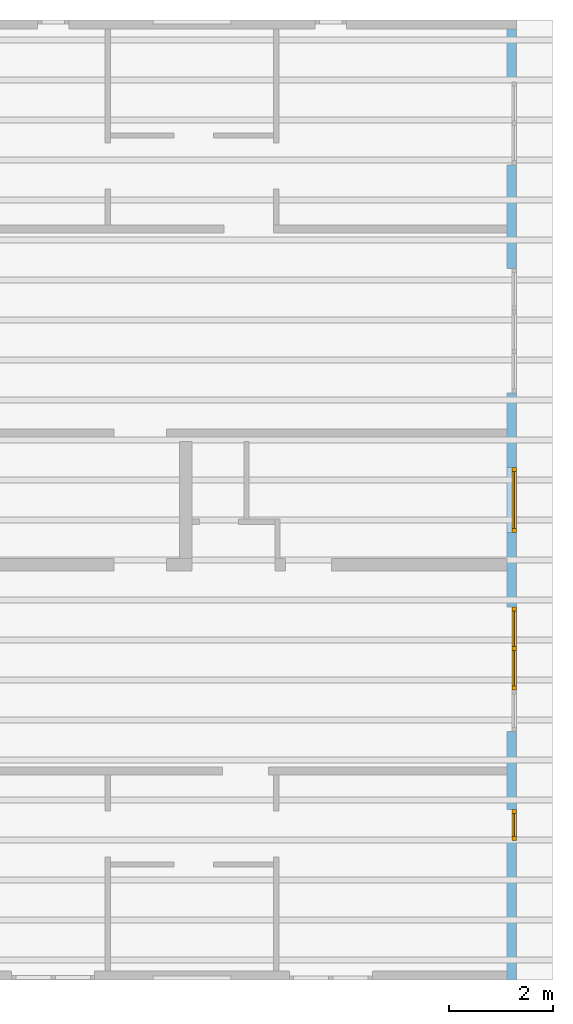
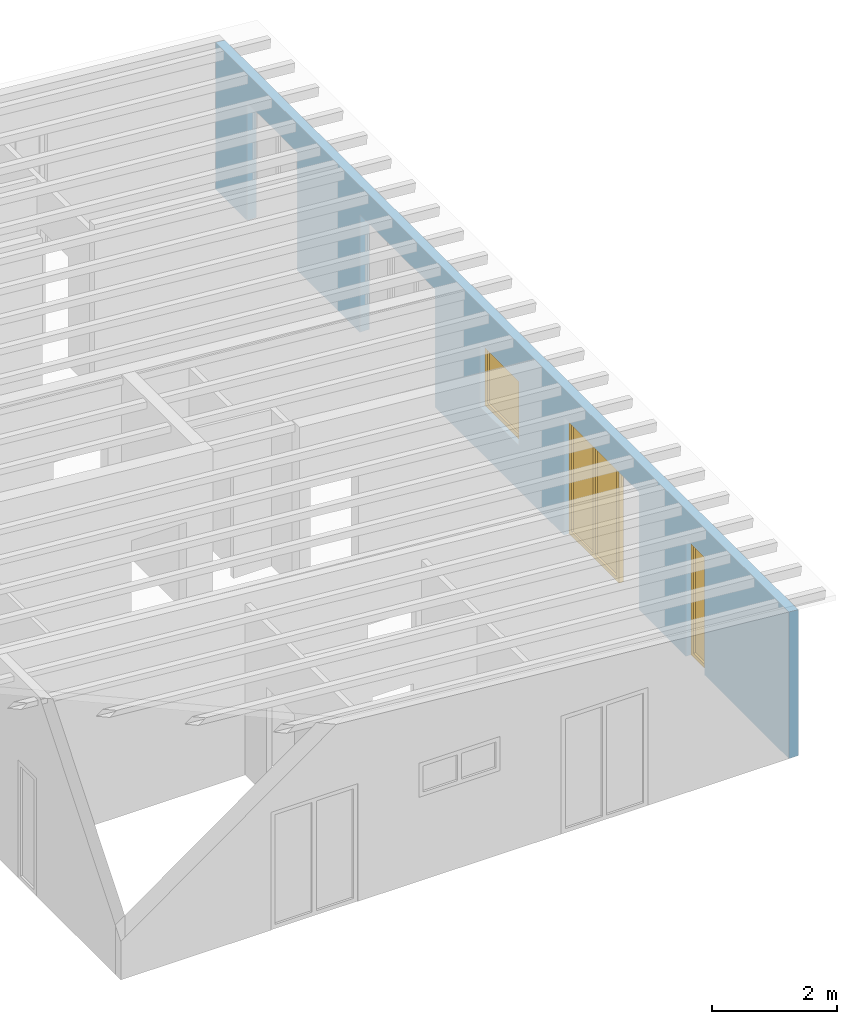
# One storey, part 9 of 13: 3 windows, 7 openings, plus 1 element that does not belong to this part.
"""IFC2X3 building model written with IfcOpenShell, lengths in millimetres."""

from ifc_helpers import new_model, entity, si_unit, converted_unit, frame, frame_2d, origin, origin_with_axes, place, context, project, spatial, rectangle, extrude, clip, halfspace, faceted_brep, material, layer, layer_set, layer_usage, element, fill, save


model = new_model("IFC2X3")

# Units and contexts
model_context = context("Model", 3, precision=1e-05, world=origin())
plan_context = context("Plan", 3, precision=1e-05, world=origin())
ifc_project = project(units=[si_unit("LENGTHUNIT", "METRE", prefix="MILLI"), converted_unit("PLANEANGLEUNIT", "DEGREE", entity("IfcPlaneAngleMeasure", 0.0174532925199433), si_unit("PLANEANGLEUNIT", "RADIAN"), dimensions=[0, 0, 0, 0, 0, 0, 0]), si_unit("AREAUNIT", "SQUARE_METRE"), si_unit("VOLUMEUNIT", "CUBIC_METRE")], contexts=[model_context, plan_context])

# Building, storey
building_placement = place(None, origin())
building = spatial("IfcBuilding", under=ifc_project, at=building_placement, CompositionType="ELEMENT")
storey_placement = place(building_placement, frame((0.0, 0.0, 4770.0), z_axis=(0.0, 0.0, 1.0), x_axis=(1.0, 0.0, 0.0)))
storey = spatial("IfcBuildingStorey", under=building, at=storey_placement, Name="Geschoss", CompositionType="ELEMENT", Elevation=4770.0)

# Wall, openings, windows
ifc_material_1 = material()
ifc_layer = layer(ifc_material_1, 175.000000044703)
ifc_layer_set = layer_set([ifc_layer])
ifc_layer_usage = layer_usage(ifc_layer_set, "AXIS2", "POSITIVE", 0.0)
wall_placement = place(storey_placement, frame((33688.3517822139, -8691.5625, 0.0), z_axis=(0.0, 0.0, 1.0), x_axis=(0.0, 1.0, 0.0)))
wall = element("IfcWallStandardCase", 1, at=wall_placement, inside=storey, material=ifc_layer_usage, context=model_context, shape_type="Clipping", body=[
    clip(extrude(rectangle(XDim=18325.0, YDim=175.000000044703, at=frame_2d((9162.5, 87.5000000223517), x_axis=(1.0, 0.0))), origin_with_axes(), (0.0, 0.0, 1.0), 2862.31051612095), halfspace(frame((18325.0, 175.000000044703, 2862.31051612095), z_axis=(0.0, 0.0871557427476584, -0.996194698091746), x_axis=(1.0, 0.0, 0.0)), True)),
])
opening_1_placement = place(wall_placement, frame((8625.0, 1.86264514923096e-09, 875.0), z_axis=(0.0, 1.0, 0.0), x_axis=(0.0, 0.0, 1.0)))
opening_1 = element("IfcOpeningElement", 2, at=opening_1_placement, cuts=wall, ObjectType="Opening", context=model_context, shape_type="SweptSolid", body=[
    extrude(rectangle(XDim=1250.0, YDim=1250.0, at=frame_2d((625.0, 625.0), x_axis=(1.0, 0.0))), origin_with_axes(), (0.0, 0.0, 1.0), 175.000000044703),
])
opening_2_placement = place(wall_placement, frame((5590.0, 0.0, 0.0), z_axis=(0.0, 1.0, 0.0), x_axis=(0.0, 0.0, 1.0)))
opening_2 = element("IfcOpeningElement", 3, at=opening_2_placement, cuts=wall, ObjectType="Opening", context=model_context, shape_type="SweptSolid", body=[
    extrude(rectangle(XDim=2300.0, YDim=1600.0, at=frame_2d((1150.0, 800.0), x_axis=(1.0, 0.0))), origin_with_axes(), (0.0, 0.0, 1.0), 175.000000044703),
])
opening_3_placement = place(wall_placement, frame((2690.0, 0.0, 0.0), z_axis=(0.0, 1.0, 0.0), x_axis=(0.0, 0.0, 1.0)))
opening_3 = element("IfcOpeningElement", 4, at=opening_3_placement, cuts=wall, ObjectType="Opening", context=model_context, shape_type="SweptSolid", body=[
    extrude(rectangle(XDim=2300.0, YDim=600.0, at=frame_2d((1150.0, 300.0), x_axis=(1.0, 0.0))), origin_with_axes(), (0.0, 0.0, 1.0), 175.000000044703),
])
opening_4_placement = place(wall_placement, frame((11310.0, 0.0, 0.0), z_axis=(0.0, 1.0, 0.0), x_axis=(0.0, 0.0, 1.0)))
element("IfcOpeningElement", 5, at=opening_4_placement, cuts=wall, ObjectType="Opening", context=model_context, shape_type="SweptSolid", body=[
    extrude(rectangle(XDim=2300.0, YDim=1600.0, at=frame_2d((1150.0, 800.0), x_axis=(1.0, 0.0))), origin_with_axes(), (0.0, 0.0, 1.0), 175.000000044703),
])
opening_5_placement = place(wall_placement, frame((15710.0, 0.0, 0.0), z_axis=(0.0, 1.0, 0.0), x_axis=(0.0, 0.0, 1.0)))
element("IfcOpeningElement", 6, at=opening_5_placement, cuts=wall, ObjectType="Opening", context=model_context, shape_type="SweptSolid", body=[
    extrude(rectangle(XDim=2300.0, YDim=1600.0, at=frame_2d((1150.0, 800.0), x_axis=(1.0, 0.0))), origin_with_axes(), (0.0, 0.0, 1.0), 175.000000044703),
])
opening_6_placement = place(wall_placement, frame((12910.0, 0.0, 0.0), z_axis=(0.0, 1.0, 0.0), x_axis=(0.0, 0.0, 1.0)))
element("IfcOpeningElement", 7, at=opening_6_placement, cuts=wall, ObjectType="Opening", context=model_context, shape_type="SweptSolid", body=[
    extrude(rectangle(XDim=2300.0, YDim=800.0, at=frame_2d((1150.0, 400.0), x_axis=(1.0, 0.0))), origin_with_axes(), (0.0, 0.0, 1.0), 175.000000044703),
])
opening_7_placement = place(wall_placement, frame((4790.0, 0.0, 0.0), z_axis=(0.0, 1.0, 0.0), x_axis=(0.0, 0.0, 1.0)))
element("IfcOpeningElement", 8, at=opening_7_placement, cuts=wall, ObjectType="Opening", context=model_context, shape_type="SweptSolid", body=[
    extrude(rectangle(XDim=2300.0, YDim=800.0, at=frame_2d((1150.0, 400.0), x_axis=(1.0, 0.0))), origin_with_axes(), (0.0, 0.0, 1.0), 175.000000044703),
])
ifc_material_2 = material()
window_1_placement = place(opening_1_placement, frame((0.0, 0.0, 0.0), z_axis=(1.0, 0.0, 0.0), x_axis=(0.0, 1.0, 0.0)))
window_1 = element("IfcWindow", 9, at=window_1_placement, inside=storey, material=ifc_material_2, Name="m", OverallHeight=1250.0, OverallWidth=1250.0, context=model_context, shape_type="Brep", body=[
    faceted_brep([(1170.0, -1.66655578226482e-12, 0.0), (1170.0, -1.66655578226482e-12, 1250.0), (1250.0, -1.68121072618987e-12, 1250.0), (1250.0, -1.68121072618987e-12, 0.0), (1250.0, 79.9999999999983, 0.0), (1250.0, 79.9999999999983, 1250.0), (1170.0, 79.9999999999983, 1250.0), (1170.0, 79.9999999999983, 0.0), (1250.0, -1.68121072618987e-12, 0.0), (1250.0, 79.9999999999983, 0.0), (1170.0, 79.9999999999983, 0.0), (1170.0, -1.66655578226482e-12, 0.0), (1250.0, -1.68121072618987e-12, 1250.0), (1250.0, 79.9999999999983, 1250.0), (1250.0, 79.9999999999983, 0.0), (1250.0, -1.68121072618987e-12, 0.0), (1170.0, -1.66655578226482e-12, 1250.0), (1170.0, 79.9999999999983, 1250.0), (1250.0, 79.9999999999983, 1250.0), (1250.0, -1.68121072618987e-12, 1250.0), (1170.0, -1.66655578226482e-12, 0.0), (1170.0, 79.9999999999983, 0.0), (1170.0, 79.9999999999983, 1250.0), (1170.0, -1.66655578226482e-12, 1250.0)], [[[0, 1, 2, 3]], [[4, 5, 6, 7]], [[8, 9, 10, 11]], [[12, 13, 14, 15]], [[16, 17, 18, 19]], [[20, 21, 22, 23]]], orient=[[False], [False], [False], [False], [False], [False]]),
    faceted_brep([(80.0, -1.46982426230124e-12, 1250.0), (80.0, -1.46982426230124e-12, 0.0), (-1.4321069287046e-14, -1.45516931837619e-12, 0.0), (-1.4321069287046e-14, -1.45516931837619e-12, 1250.0), (3.74206958822511e-16, 79.9999999999986, 1250.0), (3.74206958822511e-16, 79.9999999999986, 0.0), (80.0, 79.9999999999985, 0.0), (80.0, 79.9999999999985, 1250.0), (-1.4321069287046e-14, -1.45516931837619e-12, 1250.0), (3.74206958822511e-16, 79.9999999999986, 1250.0), (80.0, 79.9999999999985, 1250.0), (80.0, -1.46982426230124e-12, 1250.0), (-1.4321069287046e-14, -1.45516931837619e-12, 0.0), (3.74206958822511e-16, 79.9999999999986, 0.0), (3.74206958822511e-16, 79.9999999999986, 1250.0), (-1.4321069287046e-14, -1.45516931837619e-12, 1250.0), (80.0, -1.46982426230124e-12, 0.0), (80.0, 79.9999999999985, 0.0), (3.74206958822511e-16, 79.9999999999986, 0.0), (-1.4321069287046e-14, -1.45516931837619e-12, 0.0), (80.0, -1.46982426230124e-12, 1250.0), (80.0, 79.9999999999985, 1250.0), (80.0, 79.9999999999985, 0.0), (80.0, -1.46982426230124e-12, 0.0)], [[[0, 1, 2, 3]], [[4, 5, 6, 7]], [[8, 9, 10, 11]], [[12, 13, 14, 15]], [[16, 17, 18, 19]], [[20, 21, 22, 23]]], orient=[[False], [False], [False], [False], [False], [False]]),
    faceted_brep([(1170.0, -1.65589764122842e-12, 1170.0), (80.0, -1.45561340758604e-12, 1170.0), (80.0, -1.45561340758604e-12, 1250.0), (1170.0, -1.65589764122842e-12, 1250.0), (1170.0, 79.9999999999984, 1250.0), (80.0, 79.9999999999986, 1250.0), (80.0, 79.9999999999986, 1170.0), (1170.0, 79.9999999999984, 1170.0), (1170.0, -1.65589764122842e-12, 1250.0), (1170.0, 79.9999999999984, 1250.0), (1170.0, 79.9999999999984, 1170.0), (1170.0, -1.65589764122842e-12, 1170.0), (80.0, -1.45561340758604e-12, 1250.0), (80.0, 79.9999999999986, 1250.0), (1170.0, 79.9999999999984, 1250.0), (1170.0, -1.65589764122842e-12, 1250.0), (80.0, -1.45561340758604e-12, 1170.0), (80.0, 79.9999999999986, 1170.0), (80.0, 79.9999999999986, 1250.0), (80.0, -1.45561340758604e-12, 1250.0), (1170.0, -1.65589764122842e-12, 1170.0), (1170.0, 79.9999999999984, 1170.0), (80.0, 79.9999999999986, 1170.0), (80.0, -1.45561340758604e-12, 1170.0)], [[[0, 1, 2, 3]], [[4, 5, 6, 7]], [[8, 9, 10, 11]], [[12, 13, 14, 15]], [[16, 17, 18, 19]], [[20, 21, 22, 23]]], orient=[[False], [False], [False], [False], [False], [False]]),
    faceted_brep([(80.0, -1.45561340758604e-12, 80.0), (1170.0, -1.65589764122842e-12, 80.0), (1170.0, -1.65589764122842e-12, 0.0), (80.0, -1.45561340758604e-12, 0.0), (80.0, 79.9999999999986, 0.0), (1170.0, 79.9999999999984, 0.0), (1170.0, 79.9999999999984, 80.0), (80.0, 79.9999999999986, 80.0), (80.0, -1.45561340758604e-12, 0.0), (80.0, 79.9999999999986, 0.0), (80.0, 79.9999999999986, 80.0), (80.0, -1.45561340758604e-12, 80.0), (1170.0, -1.65589764122842e-12, 0.0), (1170.0, 79.9999999999984, 0.0), (80.0, 79.9999999999986, 0.0), (80.0, -1.45561340758604e-12, 0.0), (1170.0, -1.65589764122842e-12, 80.0), (1170.0, 79.9999999999984, 80.0), (1170.0, 79.9999999999984, 0.0), (1170.0, -1.65589764122842e-12, 0.0), (80.0, -1.45561340758604e-12, 80.0), (80.0, 79.9999999999986, 80.0), (1170.0, 79.9999999999984, 80.0), (1170.0, -1.65589764122842e-12, 80.0)], [[[0, 1, 2, 3]], [[4, 5, 6, 7]], [[8, 9, 10, 11]], [[12, 13, 14, 15]], [[16, 17, 18, 19]], [[20, 21, 22, 23]]], orient=[[False], [False], [False], [False], [False], [False]]),
    faceted_brep([(1170.0, 39.9999999999983, 80.0), (80.0, 39.9999999999985, 80.0), (80.0, 39.9999999999985, 1170.0), (1170.0, 39.9999999999983, 1170.0), (1170.0, 40.9999999999983, 80.0), (1170.0, 40.9999999999983, 1170.0), (80.0, 40.9999999999985, 1170.0), (80.0, 40.9999999999985, 80.0), (1170.0, 39.9999999999983, 80.0), (1170.0, 40.9999999999983, 80.0), (80.0, 40.9999999999985, 80.0), (80.0, 39.9999999999985, 80.0), (80.0, 39.9999999999985, 80.0), (80.0, 40.9999999999985, 80.0), (80.0, 40.9999999999985, 1170.0), (80.0, 39.9999999999985, 1170.0), (80.0, 39.9999999999985, 1170.0), (80.0, 40.9999999999985, 1170.0), (1170.0, 40.9999999999983, 1170.0), (1170.0, 39.9999999999983, 1170.0), (1170.0, 39.9999999999983, 1170.0), (1170.0, 40.9999999999983, 1170.0), (1170.0, 40.9999999999983, 80.0), (1170.0, 39.9999999999983, 80.0)], [[[0, 1, 2, 3]], [[4, 5, 6, 7]], [[8, 9, 10, 11]], [[12, 13, 14, 15]], [[16, 17, 18, 19]], [[20, 21, 22, 23]]], orient=[[False], [False], [False], [False], [False], [False]]),
])
fill(opening_1, window_1)
ifc_material_3 = material()
window_2_placement = place(opening_2_placement, frame((0.0, 0.0, 0.0), z_axis=(1.0, 0.0, 0.0), x_axis=(0.0, 1.0, 0.0)))
window_2 = element("IfcWindow", 10, at=window_2_placement, inside=storey, material=ifc_material_3, Name="m", OverallHeight=2300.0, OverallWidth=1600.0, context=model_context, shape_type="Brep", body=[
    faceted_brep([(1520.0, 4.14689393934964e-11, 0.0), (1520.0, 4.14689393934964e-11, 2300.0), (1600.0, 4.14542844495713e-11, 2300.0), (1600.0, 4.14542844495713e-11, 0.0), (1600.0, 80.0000000000415, 0.0), (1600.0, 80.0000000000415, 2300.0), (1520.0, 80.0000000000415, 2300.0), (1520.0, 80.0000000000415, 0.0), (1600.0, 4.14542844495713e-11, 0.0), (1600.0, 80.0000000000415, 0.0), (1520.0, 80.0000000000415, 0.0), (1520.0, 4.14689393934964e-11, 0.0), (1600.0, 4.14542844495713e-11, 2300.0), (1600.0, 80.0000000000415, 2300.0), (1600.0, 80.0000000000415, 0.0), (1600.0, 4.14542844495713e-11, 0.0), (1520.0, 4.14689393934964e-11, 2300.0), (1520.0, 80.0000000000415, 2300.0), (1600.0, 80.0000000000415, 2300.0), (1600.0, 4.14542844495713e-11, 2300.0), (1520.0, 4.14689393934964e-11, 0.0), (1520.0, 80.0000000000415, 0.0), (1520.0, 80.0000000000415, 2300.0), (1520.0, 4.14689393934964e-11, 2300.0)], [[[0, 1, 2, 3]], [[4, 5, 6, 7]], [[8, 9, 10, 11]], [[12, 13, 14, 15]], [[16, 17, 18, 19]], [[20, 21, 22, 23]]], orient=[[False], [False], [False], [False], [False], [False]]),
    faceted_brep([(80.0, 4.17335055402646e-11, 2300.0), (80.0, 4.17335055402646e-11, 0.0), (-1.10214571841424e-16, 4.17481604841896e-11, 0.0), (-1.10214571841424e-16, 4.17481604841896e-11, 2300.0), (1.45850616740271e-14, 80.0000000000418, 2300.0), (1.45850616740271e-14, 80.0000000000418, 0.0), (80.0, 80.0000000000417, 0.0), (80.0, 80.0000000000417, 2300.0), (-1.10214571841424e-16, 4.17481604841896e-11, 2300.0), (1.45850616740271e-14, 80.0000000000418, 2300.0), (80.0, 80.0000000000417, 2300.0), (80.0, 4.17335055402646e-11, 2300.0), (-1.10214571841424e-16, 4.17481604841896e-11, 0.0), (1.45850616740271e-14, 80.0000000000418, 0.0), (1.45850616740271e-14, 80.0000000000418, 2300.0), (-1.10214571841424e-16, 4.17481604841896e-11, 2300.0), (80.0, 4.17335055402646e-11, 0.0), (80.0, 80.0000000000417, 0.0), (1.45850616740271e-14, 80.0000000000418, 0.0), (-1.10214571841424e-16, 4.17481604841896e-11, 0.0), (80.0, 4.17335055402646e-11, 2300.0), (80.0, 80.0000000000417, 2300.0), (80.0, 80.0000000000417, 0.0), (80.0, 4.17335055402646e-11, 0.0)], [[[0, 1, 2, 3]], [[4, 5, 6, 7]], [[8, 9, 10, 11]], [[12, 13, 14, 15]], [[16, 17, 18, 19]], [[20, 21, 22, 23]]], orient=[[False], [False], [False], [False], [False], [False]]),
    faceted_brep([(1520.0, 4.14831502482116e-11, 2220.0), (80.0, 4.17477163949798e-11, 2220.0), (80.0, 4.17477163949798e-11, 2300.0), (1520.0, 4.14831502482116e-11, 2300.0), (1520.0, 80.0000000000415, 2300.0), (80.0, 80.0000000000418, 2300.0), (80.0, 80.0000000000418, 2220.0), (1520.0, 80.0000000000415, 2220.0), (1520.0, 4.14831502482116e-11, 2300.0), (1520.0, 80.0000000000415, 2300.0), (1520.0, 80.0000000000415, 2220.0), (1520.0, 4.14831502482116e-11, 2220.0), (80.0, 4.17477163949798e-11, 2300.0), (80.0, 80.0000000000418, 2300.0), (1520.0, 80.0000000000415, 2300.0), (1520.0, 4.14831502482116e-11, 2300.0), (80.0, 4.17477163949798e-11, 2220.0), (80.0, 80.0000000000418, 2220.0), (80.0, 80.0000000000418, 2300.0), (80.0, 4.17477163949798e-11, 2300.0), (1520.0, 4.14831502482116e-11, 2220.0), (1520.0, 80.0000000000415, 2220.0), (80.0, 80.0000000000418, 2220.0), (80.0, 4.17477163949798e-11, 2220.0)], [[[0, 1, 2, 3]], [[4, 5, 6, 7]], [[8, 9, 10, 11]], [[12, 13, 14, 15]], [[16, 17, 18, 19]], [[20, 21, 22, 23]]], orient=[[False], [False], [False], [False], [False], [False]]),
    faceted_brep([(80.0, 4.17477163949798e-11, 80.0), (1520.0, 4.14831502482116e-11, 80.0), (1520.0, 4.14831502482116e-11, 0.0), (80.0, 4.17477163949798e-11, 0.0), (80.0, 80.0000000000418, 0.0), (1520.0, 80.0000000000415, 0.0), (1520.0, 80.0000000000415, 80.0), (80.0, 80.0000000000418, 80.0), (80.0, 4.17477163949798e-11, 0.0), (80.0, 80.0000000000418, 0.0), (80.0, 80.0000000000418, 80.0), (80.0, 4.17477163949798e-11, 80.0), (1520.0, 4.14831502482116e-11, 0.0), (1520.0, 80.0000000000415, 0.0), (80.0, 80.0000000000418, 0.0), (80.0, 4.17477163949798e-11, 0.0), (1520.0, 4.14831502482116e-11, 80.0), (1520.0, 80.0000000000415, 80.0), (1520.0, 80.0000000000415, 0.0), (1520.0, 4.14831502482116e-11, 0.0), (80.0, 4.17477163949798e-11, 80.0), (80.0, 80.0000000000418, 80.0), (1520.0, 80.0000000000415, 80.0), (1520.0, 4.14831502482116e-11, 80.0)], [[[0, 1, 2, 3]], [[4, 5, 6, 7]], [[8, 9, 10, 11]], [[12, 13, 14, 15]], [[16, 17, 18, 19]], [[20, 21, 22, 23]]], orient=[[False], [False], [False], [False], [False], [False]]),
    faceted_brep([(760.0, 4.16086054499942e-11, 80.0), (760.0, 4.16086054499942e-11, 2220.0), (840.0, 4.15938394837667e-11, 2220.0), (840.0, 4.15938394837667e-11, 80.0), (840.0, 80.0000000000416, 80.0), (840.0, 80.0000000000416, 2220.0), (760.0, 80.0000000000416, 2220.0), (760.0, 80.0000000000416, 80.0), (840.0, 4.15938394837667e-11, 80.0), (840.0, 80.0000000000416, 80.0), (760.0, 80.0000000000416, 80.0), (760.0, 4.16086054499942e-11, 80.0), (840.0, 4.15938394837667e-11, 2220.0), (840.0, 80.0000000000416, 2220.0), (840.0, 80.0000000000416, 80.0), (840.0, 4.15938394837667e-11, 80.0), (760.0, 4.16086054499942e-11, 2220.0), (760.0, 80.0000000000416, 2220.0), (840.0, 80.0000000000416, 2220.0), (840.0, 4.15938394837667e-11, 2220.0), (760.0, 4.16086054499942e-11, 80.0), (760.0, 80.0000000000416, 80.0), (760.0, 80.0000000000416, 2220.0), (760.0, 4.16086054499942e-11, 2220.0)], [[[0, 1, 2, 3]], [[4, 5, 6, 7]], [[8, 9, 10, 11]], [[12, 13, 14, 15]], [[16, 17, 18, 19]], [[20, 21, 22, 23]]], orient=[[False], [False], [False], [False], [False], [False]]),
    faceted_brep([(80.0, 40.0000000000418, 2220.0), (760.0, 40.0000000000416, 2220.0), (760.0, 40.0000000000416, 80.0), (80.0, 40.0000000000418, 80.0), (80.0, 41.0000000000418, 2220.0), (80.0, 41.0000000000418, 80.0), (760.0, 41.0000000000416, 80.0), (760.0, 41.0000000000416, 2220.0), (80.0, 40.0000000000418, 2220.0), (80.0, 41.0000000000418, 2220.0), (760.0, 41.0000000000416, 2220.0), (760.0, 40.0000000000416, 2220.0), (760.0, 40.0000000000416, 2220.0), (760.0, 41.0000000000416, 2220.0), (760.0, 41.0000000000416, 80.0), (760.0, 40.0000000000416, 80.0), (760.0, 40.0000000000416, 80.0), (760.0, 41.0000000000416, 80.0), (80.0, 41.0000000000418, 80.0), (80.0, 40.0000000000418, 80.0), (80.0, 40.0000000000418, 80.0), (80.0, 41.0000000000418, 80.0), (80.0, 41.0000000000418, 2220.0), (80.0, 40.0000000000418, 2220.0)], [[[0, 1, 2, 3]], [[4, 5, 6, 7]], [[8, 9, 10, 11]], [[12, 13, 14, 15]], [[16, 17, 18, 19]], [[20, 21, 22, 23]]], orient=[[False], [False], [False], [False], [False], [False]]),
    faceted_brep([(1520.0, 40.0000000000415, 80.0), (840.0, 40.0000000000416, 80.0), (840.0, 40.0000000000416, 2220.0), (1520.0, 40.0000000000415, 2220.0), (1520.0, 41.0000000000415, 80.0), (1520.0, 41.0000000000415, 2220.0), (840.0, 41.0000000000416, 2220.0), (840.0, 41.0000000000416, 80.0), (1520.0, 40.0000000000415, 80.0), (1520.0, 41.0000000000415, 80.0), (840.0, 41.0000000000416, 80.0), (840.0, 40.0000000000416, 80.0), (840.0, 40.0000000000416, 80.0), (840.0, 41.0000000000416, 80.0), (840.0, 41.0000000000416, 2220.0), (840.0, 40.0000000000416, 2220.0), (840.0, 40.0000000000416, 2220.0), (840.0, 41.0000000000416, 2220.0), (1520.0, 41.0000000000415, 2220.0), (1520.0, 40.0000000000415, 2220.0), (1520.0, 40.0000000000415, 2220.0), (1520.0, 41.0000000000415, 2220.0), (1520.0, 41.0000000000415, 80.0), (1520.0, 40.0000000000415, 80.0)], [[[0, 1, 2, 3]], [[4, 5, 6, 7]], [[8, 9, 10, 11]], [[12, 13, 14, 15]], [[16, 17, 18, 19]], [[20, 21, 22, 23]]], orient=[[False], [False], [False], [False], [False], [False]]),
])
fill(opening_2, window_2)
ifc_material_4 = material()
window_3_placement = place(opening_3_placement, frame((0.0, 0.0, 0.0), z_axis=(1.0, 0.0, 0.0), x_axis=(0.0, 1.0, 0.0)))
window_3 = element("IfcWindow", 11, at=window_3_placement, inside=storey, material=ifc_material_4, Name="m", OverallHeight=2300.0, OverallWidth=600.0, context=model_context, shape_type="Brep", body=[
    faceted_brep([(80.0, 4.18578505190226e-11, 0.0), (0.0, 4.18726164852501e-11, 0.0), (0.0, 4.18726164852501e-11, 2300.0), (80.0, 4.18578505190226e-11, 2300.0), (0.0, 80.0000000000419, 0.0), (80.0, 80.0000000000419, 0.0), (80.0, 80.0000000000419, 2300.0), (0.0, 80.0000000000419, 2300.0), (0.0, 4.18726164852501e-11, 0.0), (80.0, 4.18578505190226e-11, 0.0), (80.0, 80.0000000000419, 0.0), (0.0, 80.0000000000419, 0.0), (0.0, 4.18726164852501e-11, 2300.0), (0.0, 4.18726164852501e-11, 0.0), (0.0, 80.0000000000419, 0.0), (0.0, 80.0000000000419, 2300.0), (80.0, 4.18578505190226e-11, 2300.0), (0.0, 4.18726164852501e-11, 2300.0), (0.0, 80.0000000000419, 2300.0), (80.0, 80.0000000000419, 2300.0), (80.0, 4.18578505190226e-11, 0.0), (80.0, 4.18578505190226e-11, 2300.0), (80.0, 80.0000000000419, 2300.0), (80.0, 80.0000000000419, 0.0)], [[[0, 1, 2, 3]], [[4, 5, 6, 7]], [[8, 9, 10, 11]], [[12, 13, 14, 15]], [[16, 17, 18, 19]], [[20, 21, 22, 23]]], orient=[[False], [False], [False], [False], [False], [False]]),
    faceted_brep([(520.0, 4.17628154281147e-11, 2300.0), (600.0, 4.17481604841896e-11, 2300.0), (600.0, 4.17481604841896e-11, 0.0), (520.0, 4.17628154281147e-11, 0.0), (600.0, 80.0000000000418, 2300.0), (520.0, 80.0000000000418, 2300.0), (520.0, 80.0000000000418, 0.0), (600.0, 80.0000000000418, 0.0), (600.0, 4.17481604841896e-11, 2300.0), (520.0, 4.17628154281147e-11, 2300.0), (520.0, 80.0000000000418, 2300.0), (600.0, 80.0000000000418, 2300.0), (600.0, 4.17481604841896e-11, 0.0), (600.0, 4.17481604841896e-11, 2300.0), (600.0, 80.0000000000418, 2300.0), (600.0, 80.0000000000418, 0.0), (520.0, 4.17628154281147e-11, 0.0), (600.0, 4.17481604841896e-11, 0.0), (600.0, 80.0000000000418, 0.0), (520.0, 80.0000000000418, 0.0), (520.0, 4.17628154281147e-11, 2300.0), (520.0, 4.17628154281147e-11, 0.0), (520.0, 80.0000000000418, 0.0), (520.0, 80.0000000000418, 2300.0)], [[[0, 1, 2, 3]], [[4, 5, 6, 7]], [[8, 9, 10, 11]], [[12, 13, 14, 15]], [[16, 17, 18, 19]], [[20, 21, 22, 23]]], orient=[[False], [False], [False], [False], [False], [False]]),
    faceted_brep([(80.0, 4.18294288095922e-11, 2220.0), (80.0, 4.18294288095922e-11, 2300.0), (520.0, 4.17486045733995e-11, 2300.0), (520.0, 4.17486045733995e-11, 2220.0), (80.0, 80.0000000000418, 2300.0), (80.0, 80.0000000000418, 2220.0), (520.0, 80.0000000000418, 2220.0), (520.0, 80.0000000000418, 2300.0), (80.0, 4.18294288095922e-11, 2300.0), (80.0, 4.18294288095922e-11, 2220.0), (80.0, 80.0000000000418, 2220.0), (80.0, 80.0000000000418, 2300.0), (520.0, 4.17486045733995e-11, 2300.0), (80.0, 4.18294288095922e-11, 2300.0), (80.0, 80.0000000000418, 2300.0), (520.0, 80.0000000000418, 2300.0), (520.0, 4.17486045733995e-11, 2220.0), (520.0, 4.17486045733995e-11, 2300.0), (520.0, 80.0000000000418, 2300.0), (520.0, 80.0000000000418, 2220.0), (80.0, 4.18294288095922e-11, 2220.0), (520.0, 4.17486045733995e-11, 2220.0), (520.0, 80.0000000000418, 2220.0), (80.0, 80.0000000000418, 2220.0)], [[[0, 1, 2, 3]], [[4, 5, 6, 7]], [[8, 9, 10, 11]], [[12, 13, 14, 15]], [[16, 17, 18, 19]], [[20, 21, 22, 23]]], orient=[[False], [False], [False], [False], [False], [False]]),
    faceted_brep([(520.0, 4.17486045733995e-11, 80.0), (520.0, 4.17486045733995e-11, 0.0), (80.0, 4.18294288095922e-11, 0.0), (80.0, 4.18294288095922e-11, 80.0), (520.0, 80.0000000000418, 0.0), (520.0, 80.0000000000418, 80.0), (80.0, 80.0000000000418, 80.0), (80.0, 80.0000000000418, 0.0), (520.0, 4.17486045733995e-11, 0.0), (520.0, 4.17486045733995e-11, 80.0), (520.0, 80.0000000000418, 80.0), (520.0, 80.0000000000418, 0.0), (80.0, 4.18294288095922e-11, 0.0), (520.0, 4.17486045733995e-11, 0.0), (520.0, 80.0000000000418, 0.0), (80.0, 80.0000000000418, 0.0), (80.0, 4.18294288095922e-11, 80.0), (80.0, 4.18294288095922e-11, 0.0), (80.0, 80.0000000000418, 0.0), (80.0, 80.0000000000418, 80.0), (520.0, 4.17486045733995e-11, 80.0), (80.0, 4.18294288095922e-11, 80.0), (80.0, 80.0000000000418, 80.0), (520.0, 80.0000000000418, 80.0)], [[[0, 1, 2, 3]], [[4, 5, 6, 7]], [[8, 9, 10, 11]], [[12, 13, 14, 15]], [[16, 17, 18, 19]], [[20, 21, 22, 23]]], orient=[[False], [False], [False], [False], [False], [False]]),
    faceted_brep([(80.0, 40.0000000000418, 80.0), (80.0, 40.0000000000418, 2220.0), (520.0, 40.0000000000418, 2220.0), (520.0, 40.0000000000418, 80.0), (80.0, 41.0000000000418, 80.0), (520.0, 41.0000000000418, 80.0), (520.0, 41.0000000000418, 2220.0), (80.0, 41.0000000000418, 2220.0), (80.0, 40.0000000000418, 80.0), (80.0, 41.0000000000418, 80.0), (80.0, 41.0000000000418, 2220.0), (80.0, 40.0000000000418, 2220.0), (80.0, 40.0000000000418, 2220.0), (80.0, 41.0000000000418, 2220.0), (520.0, 41.0000000000418, 2220.0), (520.0, 40.0000000000418, 2220.0), (520.0, 40.0000000000418, 2220.0), (520.0, 41.0000000000418, 2220.0), (520.0, 41.0000000000418, 80.0), (520.0, 40.0000000000418, 80.0), (520.0, 40.0000000000418, 80.0), (520.0, 41.0000000000418, 80.0), (80.0, 41.0000000000418, 80.0), (80.0, 40.0000000000418, 80.0)], [[[0, 1, 2, 3]], [[4, 5, 6, 7]], [[8, 9, 10, 11]], [[12, 13, 14, 15]], [[16, 17, 18, 19]], [[20, 21, 22, 23]]], orient=[[False], [False], [False], [False], [False], [False]]),
])
fill(opening_3, window_3)

save(model, "model.ifc")
